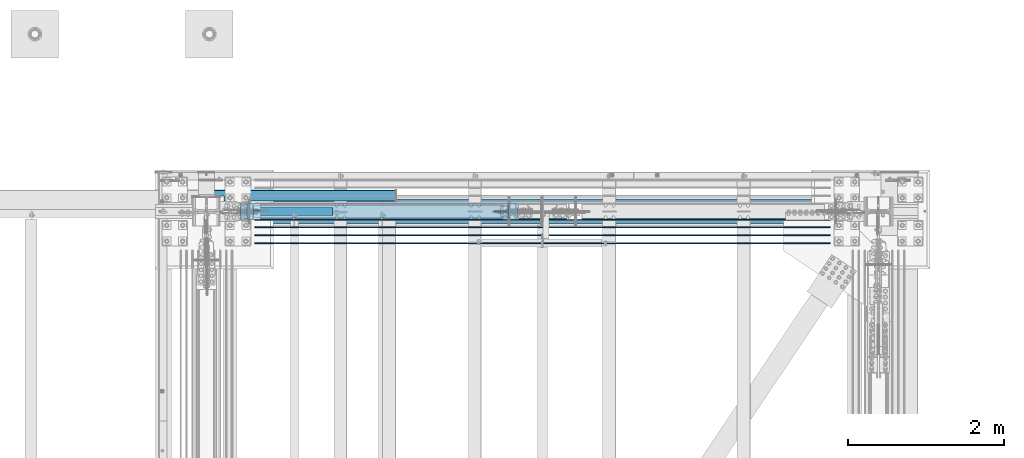
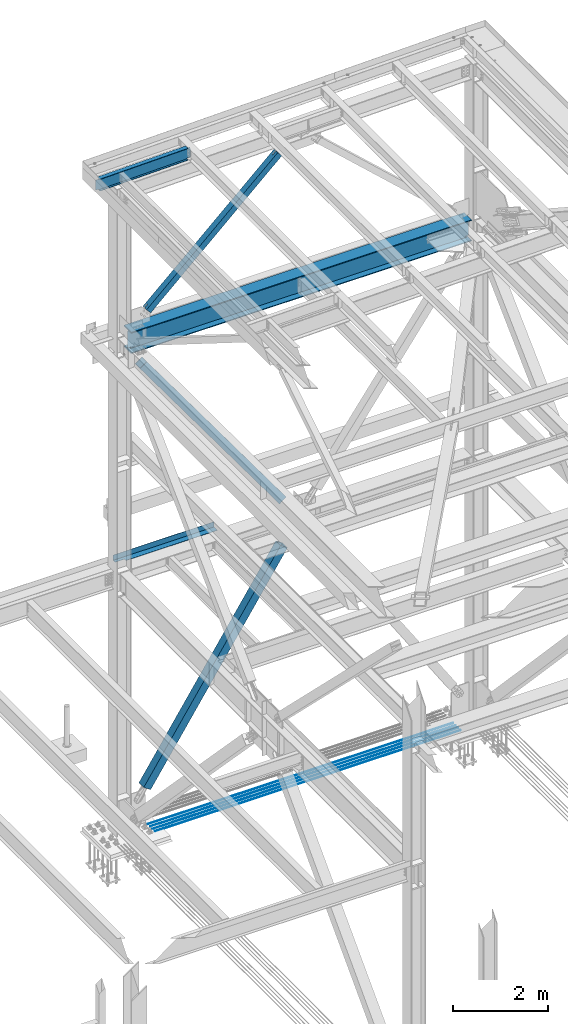
# One storey, part 1997 of 3843: 7 beams, 3 members, 10 elements without a shape of their own.
"""IFC2X3 building model written with IfcOpenShell, lengths in millimetres."""

from ifc_helpers import new_model, si_unit, frame, origin_with_axes, place, context, subcontext, project, spatial, faceted_brep, material, type_object, element, aggregate, save


model = new_model("IFC2X3")

# Units and contexts
model_context = context("Model", 3, precision=1e-05, world=origin_with_axes())
body_context = subcontext(model_context, "Body", "Model", "MODEL_VIEW")
ifc_project = project(units=[si_unit("LENGTHUNIT", "METRE", prefix="MILLI"), si_unit("AREAUNIT", "SQUARE_METRE"), si_unit("VOLUMEUNIT", "CUBIC_METRE"), si_unit("MASSUNIT", "GRAM", prefix="KILO"), si_unit("TIMEUNIT", "SECOND"), si_unit("PLANEANGLEUNIT", "RADIAN"), si_unit("SOLIDANGLEUNIT", "STERADIAN"), si_unit("THERMODYNAMICTEMPERATUREUNIT", "DEGREE_CELSIUS"), si_unit("LUMINOUSINTENSITYUNIT", "LUMEN")], contexts=[model_context])

# Site, building, storey
site_placement = place(None, origin_with_axes())
site = spatial("IfcSite", under=ifc_project, at=site_placement, CompositionType="ELEMENT")
building_placement = place(site_placement, origin_with_axes())
building = spatial("IfcBuilding", under=site, at=building_placement, Name="Undefined", CompositionType="ELEMENT")
storey_placement = place(building_placement, origin_with_axes())
storey = spatial("IfcBuildingStorey", under=building, at=storey_placement, Name="Undefined", CompositionType="ELEMENT", Elevation=0.0)

# Assembly, beam
assembly_1_placement = place(storey_placement, origin_with_axes())
assembly_1 = element("IfcElementAssembly", 1, at=assembly_1_placement, inside=storey, Name="REBAR", AssemblyPlace="NOTDEFINED", PredefinedType="RIGID_FRAME")
ifc_material_1 = material(Name="STEEL/A706-60")
beam_type_1 = type_object("IfcBeamType", Name="#10 REBAR", PredefinedType="NOTDEFINED")
beam_1_placement = place(assembly_1_placement, frame((77635.0999804674, 104152.7, 29700.5375), z_axis=(0.0, 0.0, 1.0), x_axis=(1.0, 0.0, 0.0)))
beam_1 = element("IfcBeam", 2, at=beam_1_placement, type_object=beam_type_1, material=ifc_material_1, Name="REBAR", ObjectType="#10 REBAR", context=body_context, shape_type="Brep", body=[
    faceted_brep([(0.0, -7.9375, 0.0), (0.0, -5.61266007566883, -5.61266007566883), (7391.48749999408, -5.61266007566883, -5.61266007566883), (7391.48749999408, -7.9375, 0.0), (0.0, 0.0, -7.9375), (7391.48749999408, 0.0, -7.9375), (0.0, 5.61266007566883, -5.61266007566883), (7391.48749999408, 5.61266007566883, -5.61266007566883), (0.0, 7.9375, 0.0), (7391.48749999408, 7.9375, 0.0), (0.0, 5.61266007566883, 5.61266007566883), (7391.48749999408, 5.61266007566883, 5.61266007566883), (0.0, 0.0, 7.9375), (7391.48749999408, 0.0, 7.9375), (0.0, -5.61266007566883, 5.61266007566883), (7391.48749999408, -5.61266007566883, 5.61266007566883)], [[[0, 1, 2, 3]], [[1, 4, 5, 2]], [[4, 6, 7, 5]], [[6, 8, 9, 7]], [[8, 10, 11, 9]], [[10, 12, 13, 11]], [[12, 14, 15, 13]], [[14, 0, 3, 15]], [[5, 7, 9, 11, 13, 15, 3, 2]], [[14, 12, 10, 8, 6, 4, 1, 0]]]),
])
aggregate(assembly_1, [beam_1])

assembly_2_placement = place(storey_placement, origin_with_axes())
assembly_2 = element("IfcElementAssembly", 3, at=assembly_2_placement, inside=storey, Name="REBAR", AssemblyPlace="NOTDEFINED", PredefinedType="RIGID_FRAME")
beam_2_placement = place(assembly_2_placement, frame((77635.0999804674, 104254.3, 29700.5375), z_axis=(0.0, 0.0, 1.0), x_axis=(1.0, 0.0, 0.0)))
beam_2 = element("IfcBeam", 4, at=beam_2_placement, type_object=beam_type_1, material=ifc_material_1, Name="REBAR", ObjectType="#10 REBAR", context=body_context, shape_type="Brep", body=[
    faceted_brep([(0.0, -7.9375, 0.0), (0.0, -5.61266007566883, -5.61266007566883), (7391.48749999408, -5.61266007566883, -5.61266007566883), (7391.48749999408, -7.9375, 0.0), (0.0, 0.0, -7.9375), (7391.48749999408, 0.0, -7.9375), (0.0, 5.61266007566883, -5.61266007566883), (7391.48749999408, 5.61266007566883, -5.61266007566883), (0.0, 7.9375, 0.0), (7391.48749999408, 7.9375, 0.0), (0.0, 5.61266007566883, 5.61266007566883), (7391.48749999408, 5.61266007566883, 5.61266007566883), (0.0, 0.0, 7.9375), (7391.48749999408, 0.0, 7.9375), (0.0, -5.61266007566883, 5.61266007566883), (7391.48749999408, -5.61266007566883, 5.61266007566883)], [[[0, 1, 2, 3]], [[1, 4, 5, 2]], [[4, 6, 7, 5]], [[6, 8, 9, 7]], [[8, 10, 11, 9]], [[10, 12, 13, 11]], [[12, 14, 15, 13]], [[14, 0, 3, 15]], [[5, 7, 9, 11, 13, 15, 3, 2]], [[14, 12, 10, 8, 6, 4, 1, 0]]]),
])
aggregate(assembly_2, [beam_2])

assembly_3_placement = place(storey_placement, origin_with_axes())
assembly_3 = element("IfcElementAssembly", 5, at=assembly_3_placement, inside=storey, Name="REBAR", AssemblyPlace="NOTDEFINED", PredefinedType="RIGID_FRAME")
beam_3_placement = place(assembly_3_placement, frame((77635.0999804674, 104355.9, 29700.5375), z_axis=(0.0, 0.0, 1.0), x_axis=(1.0, 0.0, 0.0)))
beam_3 = element("IfcBeam", 6, at=beam_3_placement, type_object=beam_type_1, material=ifc_material_1, Name="REBAR", ObjectType="#10 REBAR", context=body_context, shape_type="Brep", body=[
    faceted_brep([(0.0, -7.9375, 0.0), (0.0, -5.61266007566883, -5.61266007566883), (7391.48749999408, -5.61266007566883, -5.61266007566883), (7391.48749999408, -7.9375, 0.0), (0.0, 0.0, -7.9375), (7391.48749999408, 0.0, -7.9375), (0.0, 5.61266007566883, -5.61266007566883), (7391.48749999408, 5.61266007566883, -5.61266007566883), (0.0, 7.9375, 0.0), (7391.48749999408, 7.9375, 0.0), (0.0, 5.61266007566883, 5.61266007566883), (7391.48749999408, 5.61266007566883, 5.61266007566883), (0.0, 0.0, 7.9375), (7391.48749999408, 0.0, 7.9375), (0.0, -5.61266007566883, 5.61266007566883), (7391.48749999408, -5.61266007566883, 5.61266007566883)], [[[0, 1, 2, 3]], [[1, 4, 5, 2]], [[4, 6, 7, 5]], [[6, 8, 9, 7]], [[8, 10, 11, 9]], [[10, 12, 13, 11]], [[12, 14, 15, 13]], [[14, 0, 3, 15]], [[5, 7, 9, 11, 13, 15, 3, 2]], [[14, 12, 10, 8, 6, 4, 1, 0]]]),
])
aggregate(assembly_3, [beam_3])

assembly_4_placement = place(storey_placement, origin_with_axes())
assembly_4 = element("IfcElementAssembly", 7, at=assembly_4_placement, inside=storey, Name="REBAR", AssemblyPlace="NOTDEFINED", PredefinedType="RIGID_FRAME")
beam_4_placement = place(assembly_4_placement, frame((77635.0999804674, 104457.5, 29700.5375), z_axis=(0.0, 0.0, 1.0), x_axis=(1.0, 0.0, 0.0)))
beam_4 = element("IfcBeam", 8, at=beam_4_placement, type_object=beam_type_1, material=ifc_material_1, Name="REBAR", ObjectType="#10 REBAR", context=body_context, shape_type="Brep", body=[
    faceted_brep([(0.0, -7.9375, 0.0), (0.0, -5.61266007566883, -5.61266007566883), (7391.48749999408, -5.61266007566883, -5.61266007566883), (7391.48749999408, -7.9375, 0.0), (0.0, 0.0, -7.9375), (7391.48749999408, 0.0, -7.9375), (0.0, 5.61266007566883, -5.61266007566883), (7391.48749999408, 5.61266007566883, -5.61266007566883), (0.0, 7.9375, 0.0), (7391.48749999408, 7.9375, 0.0), (0.0, 5.61266007566883, 5.61266007566883), (7391.48749999408, 5.61266007566883, 5.61266007566883), (0.0, 0.0, 7.9375), (7391.48749999408, 0.0, 7.9375), (0.0, -5.61266007566883, 5.61266007566883), (7391.48749999408, -5.61266007566883, 5.61266007566883)], [[[0, 1, 2, 3]], [[1, 4, 5, 2]], [[4, 6, 7, 5]], [[6, 8, 9, 7]], [[8, 10, 11, 9]], [[10, 12, 13, 11]], [[12, 14, 15, 13]], [[14, 0, 3, 15]], [[5, 7, 9, 11, 13, 15, 3, 2]], [[14, 12, 10, 8, 6, 4, 1, 0]]]),
])
aggregate(assembly_4, [beam_4])

assembly_5_placement = place(storey_placement, origin_with_axes())
assembly_5 = element("IfcElementAssembly", 9, at=assembly_5_placement, inside=storey, Name="BEAM", AssemblyPlace="NOTDEFINED", PredefinedType="RIGID_FRAME")
ifc_material_2 = material(Name="STEEL/A992")
beam_type_2 = type_object("IfcBeamType", Name="W21X101", PredefinedType="NOTDEFINED")
beam_5_placement = place(assembly_5_placement, frame((77012.8, 104559.1, 42197.3375), z_axis=(0.0, 0.0, 1.0), x_axis=(1.0, 0.0, 0.0)))
beam_5 = element("IfcBeam", 10, at=beam_5_placement, type_object=beam_type_2, material=ifc_material_2, Name="BEAM", ObjectType="W21X101", context=body_context, shape_type="Brep", body=[
    faceted_brep([(199.239600281406, -155.574999999997, 271.462500000001), (199.239600281406, 155.574999999997, 271.462500000001), (187.324999999997, 155.574999999997, 250.824999999997), (187.324999999997, 6.35000000000582, 250.824999999997), (187.324999999997, -6.35000000000582, 250.824999999997), (187.324999999997, -155.574999999997, 250.824999999997), (8442.32500000003, -155.574999999997, -271.462500000001), (8430.41038480254, -155.574999999997, -250.824999999997), (199.239615197468, -155.574999999997, -250.824999999997), (187.324999999997, -155.574999999997, -271.462500000001), (8442.32500000003, 155.574999999997, -271.462500000001), (187.324999999997, 155.574999999997, -271.462500000001), (8430.41038480254, 155.574999999997, -250.824999999997), (199.239615197468, 155.574999999997, -250.824999999997), (8430.41038480254, 6.35000000000582, -250.824999999997), (199.239615197468, 6.35000000000582, -250.824999999997), (8430.1811927738, 6.35000000000582, -250.427999944863), (8430.1811927738, -6.34999999999127, -250.427999944863), (8430.41038480254, -6.35000000000582, -250.824999999997), (8407.72699700929, 6.35000000003492, -250.427999877924), (8407.72699700929, -6.34999999999127, -250.427999877924), (8362.34209307106, 6.35000000003492, -234.406795662093), (8362.34209307106, -6.34999999999127, -234.406795662093), (8358.05273064335, 6.35000000003492, -231.347328768315), (8358.05273064335, -6.34999999999127, -231.347328768315), (8356.0458763951, 6.35000000003492, -226.475829642106), (8356.0458763951, -6.34999999999127, -226.475829642106), (8356.93555978866, 6.35000000003492, -221.282812102218), (8356.93555978866, -6.34999999999127, -221.282812102218), (8360.44956782385, 6.35000000003492, -217.357163717686), (8360.44956782385, -6.34999999999127, -217.357163717686), (8365.5127330009, 6.35000000003492, -215.899999999994), (8365.5127330009, -6.34999999999127, -215.899999999994), (8442.32500000003, -6.34999999999127, -215.900000000001), (8434.99265158315, 6.35000000006403, -215.900000000001), (8434.99265158315, 6.35000000006403, 215.900000000001), (8442.325, -6.34999999996217, 215.900000000001), (8365.1857385246, 6.35000000003492, 215.899999999994), (8365.1857385246, -6.34999999999127, 215.899999999994), (8360.12257336729, 6.35000000003492, 217.357163705296), (8360.12257336729, -6.34999999999127, 217.357163705296), (8356.60856533264, 6.35000000003492, 221.282812060221), (8356.60856533264, -6.34999999999127, 221.282812060221), (8355.71888191109, 6.35000000003492, 226.47582957257), (8355.71888191109, -6.34999999999127, 226.47582957257), (8357.72573610905, 6.35000000003492, 231.34732869525), (8357.72573610905, -6.34999999999127, 231.34732869525), (8362.0150984848, 6.35000000003492, 234.406795623283), (8362.0150984848, -6.34999999999127, 234.406795623283), (8407.40000076295, 6.35000000003492, 250.427999877924), (8407.40000076295, -6.34999999999127, 250.427999877924), (8442.32500000003, 6.35000000000582, 250.427999981221), (8442.32500000003, -6.34999999999127, 250.427999981221), (8442.32500000003, 6.35000000000582, 250.824999999997), (8442.32500000003, -6.35000000000582, 250.824999999997), (8442.32500000003, -155.574999999997, 250.824999999997), (8442.32500000003, 155.574999999997, 250.824999999997), (8430.41039971862, 155.574999999997, 271.462500000001), (8430.41039971862, -155.574999999997, 271.462500000001), (187.324999999997, 6.35000000000582, 250.427999981221), (187.324999999997, -6.35000000000582, 250.427999981221), (222.249999237058, 6.34999999999127, 250.427999877924), (222.249999237058, -6.35000000000582, 250.427999877924), (267.634901515208, 6.34999999999127, 234.406795623283), (267.634901515208, -6.35000000000582, 234.406795623283), (271.924263890964, 6.34999999999127, 231.34732869525), (271.924263890964, -6.35000000000582, 231.34732869525), (273.93111808892, 6.34999999999127, 226.47582957257), (273.93111808892, -6.35000000000582, 226.47582957257), (273.041434667364, 6.34999999999127, 221.282812060221), (273.041434667364, -6.35000000000582, 221.282812060221), (269.527426632703, 6.34999999999127, 217.357163705296), (269.527426632703, -6.35000000000582, 217.357163705296), (264.464261475412, 6.34999999999127, 215.899999999994), (264.464261475412, -6.35000000000582, 215.899999999994), (194.657348416848, 6.35000000002037, 215.900000000001), (187.324999999997, -6.35000000000582, 215.900000000001), (194.657348416848, 6.35000000002037, -215.900000000001), (187.324999999997, -6.35000000000582, -215.900000000001), (264.137266999111, 6.34999999999127, -215.899999999994), (264.137266999111, -6.35000000000582, -215.899999999994), (269.200432176163, 6.34999999999127, -217.357163717686), (269.200432176163, -6.35000000000582, -217.357163717686), (272.714440211348, 6.34999999999127, -221.282812102218), (272.714440211348, -6.35000000000582, -221.282812102218), (273.604123604906, 6.34999999999127, -226.475829642106), (273.604123604906, -6.35000000000582, -226.475829642106), (271.597269356658, 6.34999999999127, -231.347328768315), (271.597269356658, -6.35000000000582, -231.347328768315), (267.307906928967, 6.34999999999127, -234.406795662093), (267.307906928967, -6.35000000000582, -234.406795662093), (221.923002990719, 6.34999999999127, -250.427999877924), (221.923002990719, -6.35000000000582, -250.427999877924), (199.468807226207, 6.34999999999127, -250.427999944863), (199.468807226207, -6.35000000000582, -250.427999944863), (199.239615197468, -6.35000000000582, -250.824999999997)], [[[0, 1, 2, 3, 4, 5]], [[6, 7, 8, 9]], [[10, 6, 9, 11]], [[12, 10, 11, 13]], [[14, 12, 13, 15]], [[6, 10, 12, 14, 16, 17, 18, 7]], [[19, 20, 17, 16]], [[20, 19, 21, 22]], [[22, 21, 23, 24]], [[24, 23, 25, 26]], [[26, 25, 27, 28]], [[28, 27, 29, 30]], [[30, 29, 31, 32]], [[33, 32, 31, 34]], [[33, 34, 35, 36]], [[36, 35, 37, 38]], [[38, 37, 39, 40]], [[40, 39, 41, 42]], [[42, 41, 43, 44]], [[44, 43, 45, 46]], [[46, 45, 47, 48]], [[48, 47, 49, 50]], [[50, 49, 51, 52]], [[52, 51, 53, 54]], [[55, 54, 53, 56, 57, 58]], [[55, 58, 0, 5]], [[54, 55, 5, 4]], [[59, 60, 4, 3]], [[61, 62, 60, 59]], [[62, 61, 63, 64]], [[64, 63, 65, 66]], [[66, 65, 67, 68]], [[68, 67, 69, 70]], [[70, 69, 71, 72]], [[72, 71, 73, 74]], [[74, 73, 75, 76]], [[77, 78, 76, 75]], [[78, 77, 79, 80]], [[80, 79, 81, 82]], [[82, 81, 83, 84]], [[84, 83, 85, 86]], [[86, 85, 87, 88]], [[88, 87, 89, 90]], [[90, 89, 91, 92]], [[92, 91, 93, 94]], [[18, 17, 20, 22, 24, 26, 28, 30, 32, 33, 36, 38, 40, 42, 44, 46, 48, 50, 52, 54, 4, 60, 62, 64, 66, 68, 70, 72, 74, 76, 78, 80, 82, 84, 86, 88, 90, 92, 94, 95]], [[7, 18, 95, 8]], [[94, 93, 15, 13, 11, 9, 8, 95]], [[91, 89, 87, 85, 83, 81, 79, 77, 75, 73, 71, 69, 67, 65, 63, 61, 59, 3, 53, 51, 49, 47, 45, 43, 41, 39, 37, 35, 34, 31, 29, 27, 25, 23, 21, 19, 16, 14, 15, 93]], [[56, 53, 3, 2]], [[57, 56, 2, 1]], [[58, 57, 1, 0]]]),
])
aggregate(assembly_5, [beam_5])

assembly_6_placement = place(storey_placement, origin_with_axes())
assembly_6 = element("IfcElementAssembly", 11, at=assembly_6_placement, inside=storey, Name="BEAM", AssemblyPlace="NOTDEFINED", PredefinedType="RIGID_FRAME")
beam_type_3 = type_object("IfcBeamType", Name="W12X19", PredefinedType="NOTDEFINED")
beam_6_placement = place(assembly_6_placement, frame((76406.4571597858, 104559.1, 46418.2589406452), z_axis=(-0.0211520980073474, 0.0, 0.999776269347241), x_axis=(0.999776270257024, 0.0, 0.0211520550054619)))
beam_6 = element("IfcBeam", 12, at=beam_6_placement, type_object=beam_type_3, material=ifc_material_2, Name="BEAM", ObjectType="W12X19", context=body_context, shape_type="Brep", body=[
    faceted_brep([(2232.3149825334, -3.17500000000291, -144.462499991867), (2232.3149825334, -50.8000000000029, -144.462499991867), (2232.31498253353, -50.8000000000029, -153.987499991876), (2232.31498253353, 50.8000000000029, -153.987499991876), (2232.3149825334, 50.8000000000029, -144.462499991867), (2232.3149825334, 3.17500000000291, -144.462499991867), (2232.31498253338, 3.17500000000291, -141.287499725579), (2232.31498253338, -3.17500000000291, -141.287499725579), (2233.28171245592, 3.17500000000291, -136.427420207467), (2233.28171245592, -3.17500000000291, -136.427420207467), (2236.03472635635, 3.17500000000291, -132.307243739255), (2236.03472635635, -3.17500000000291, -132.307243739255), (2240.15490282445, 3.17500000000291, -129.554229838737), (2240.15490282445, -3.17500000000291, -129.554229838737), (2245.01498234246, 3.17500000000291, -128.587499916146), (2245.01498234246, -3.17500000000291, -128.587499916146), (2314.86498100203, -3.17500000000291, -128.587499916357), (2314.86498100203, 3.17500000000291, -128.587499916357), (96.8374980314547, 3.17500000000291, 144.462500000489), (96.8374980314547, 50.8000000000029, 144.462500000489), (2232.31498253648, 50.8000000000029, 144.462500008405), (2232.31498253648, 3.17500000000291, 144.462500008405), (96.8374977455387, -3.17500000000291, -141.287499907492), (96.8374977455387, 3.17500000000291, -141.287499907492), (96.8374977423518, 3.17500000000291, -144.462499999776), (96.8374977423518, 50.8000000000029, -144.462499999776), (96.8374977328203, 50.8000000000029, -153.987499999792), (96.8374977328203, -50.8000000000029, -153.987499999792), (96.8374977423518, -50.8000000000029, -144.462499999776), (96.8374977423518, -3.17500000000291, -144.462499999776), (95.8707678278151, -3.17500000000291, -136.427420388471), (95.8707678278151, 3.17500000000291, -136.427420388471), (93.1177539315104, -3.17500000000291, -132.307243917545), (93.1177539315104, 3.17500000000291, -132.307243917545), (88.9975774661289, -3.17500000000291, -129.554230012938), (88.9975774661289, 3.17500000000291, -129.554230012938), (84.1374979491229, -3.17500000000291, -128.587500085479), (84.1374979491229, 3.17500000000291, -128.587500085479), (20.6374979119428, -3.17500000000291, -128.587500021946), (20.6374979119428, 3.17500000000291, -128.587500021946), (20.637498196942, -3.17499999998836, -114.712499731744), (20.637499580218, -3.17499999998836, 115.887500264478), (20.637499711811, -3.17500000000291, 128.587499979069), (20.637499711811, 3.17500000000291, 128.587499979069), (84.1374982064444, -3.17500000000291, 128.587499915513), (84.1374982064444, 3.17500000000291, 128.587499915513), (88.9975777254003, -3.17500000000291, 129.554229833244), (88.9975777254003, 3.17500000000291, 129.554229833244), (93.1177541962679, -3.17500000000291, 132.307243729607), (93.1177541962679, 3.17500000000291, 132.307243729607), (95.8707681008382, -3.17500000000291, 136.427420195025), (95.8707681008382, 3.17500000000291, 136.427420195025), (96.8374980282824, -3.17500000000291, 141.287499712118), (96.8374980282824, 3.17500000000291, 141.287499712118), (96.8374980410154, -50.8000000000029, 153.987499285155), (96.8374980410008, 50.8000000000029, 153.987500000498), (96.8374980314547, -3.17500000000291, 144.462500000489), (96.8374980314547, -50.8000000000029, 144.462500000489), (2232.31498253648, -3.17500000000291, 144.462500008405), (2232.31498253648, -50.8000000000029, 144.462500008405), (2232.31498253638, -50.8000000000029, 153.987499981791), (2232.31498253639, 50.8000000000029, 153.987500008421), (2232.31498253651, -3.17500000000291, 141.28749989366), (2232.31498253651, 3.17500000000291, 141.28749989366), (2233.28171245912, -3.17500000000291, 136.427420375658), (2233.28171245912, 3.17500000000291, 136.427420375658), (2236.03472635955, -3.17500000000291, 132.30724390754), (2236.03472635955, 3.17500000000291, 132.30724390754), (2240.15490282758, -3.17500000000291, 129.554230007096), (2240.15490282758, 3.17500000000291, 129.554230007096), (2245.0149823455, -3.17500000000291, 128.587500084504), (2245.0149823455, 3.17500000000291, 128.587500084504), (2314.86498280188, -3.17500000000291, 128.58750008425), (2314.86498280188, 3.17500000000291, 128.58750008425), (2314.86498270548, -3.17499999998836, 115.887499732082), (2314.86498132217, -3.17499999998836, -114.712500265654)], [[[0, 1, 2, 3, 4, 5, 6, 7]], [[7, 6, 8, 9]], [[9, 8, 10, 11]], [[11, 10, 12, 13]], [[13, 12, 14, 15]], [[16, 15, 14, 17]], [[18, 19, 20, 21]], [[22, 23, 24, 25, 26, 27, 28, 29]], [[30, 31, 23, 22]], [[32, 33, 31, 30]], [[34, 35, 33, 32]], [[36, 37, 35, 34]], [[38, 39, 37, 36]], [[40, 41, 42, 43, 39, 38]], [[44, 45, 43, 42]], [[46, 47, 45, 44]], [[48, 49, 47, 46]], [[50, 51, 49, 48]], [[52, 53, 51, 50]], [[54, 55, 19, 18, 53, 52, 56, 57]], [[57, 56, 58, 59]], [[54, 57, 59, 60]], [[55, 54, 60, 61]], [[19, 55, 61, 20]], [[60, 59, 58, 62, 63, 21, 20, 61]], [[64, 65, 63, 62]], [[66, 67, 65, 64]], [[68, 69, 67, 66]], [[70, 71, 69, 68]], [[72, 73, 71, 70]], [[73, 72, 74, 75, 16, 17]], [[12, 10, 8, 6, 5, 24, 23, 31, 33, 35, 37, 39, 43, 45, 47, 49, 51, 53, 18, 21, 63, 65, 67, 69, 71, 73, 17, 14]], [[25, 24, 5, 4]], [[26, 25, 4, 3]], [[27, 26, 3, 2]], [[28, 27, 2, 1]], [[29, 28, 1, 0]], [[75, 74, 72, 70, 68, 66, 64, 62, 58, 56, 52, 50, 48, 46, 44, 42, 41, 40, 38, 36, 34, 32, 30, 22, 29, 0, 7, 9, 11, 13, 15, 16]]]),
])
aggregate(assembly_6, [beam_6])

# Assembly, member
assembly_7_placement = place(storey_placement, origin_with_axes())
assembly_7 = element("IfcElementAssembly", 13, at=assembly_7_placement, inside=storey, Name="None", AssemblyPlace="NOTDEFINED", PredefinedType="RIGID_FRAME")
member_type_1 = type_object("IfcMemberType", Name="HSS8X8X3/16", PredefinedType="NOTDEFINED")
member_1_placement = place(assembly_7_placement, frame((80905.3945590918, 104559.1, 36837.8644556643), z_axis=(0.0, 1.0, 0.0), x_axis=(-0.587657745235489, 0.0, 0.809109618324206)))
member_1 = element("IfcMember", 14, at=member_1_placement, type_object=member_type_1, material=ifc_material_2, Name="None", ObjectType="HSS8X8X3/16", context=body_context, shape_type="Brep", body=[
    faceted_brep([(2.03726813197136e-10, 96.8375000003298, -96.8374999999942), (-2.18278728425503e-10, -96.837500000317, -96.8374999999942), (5746.74999994003, -96.8374999603548, -96.8374999999942), (5746.74999994067, 96.8375000390515, -96.8374999999942), (-2.18278728425503e-10, -96.837500000317, 96.8374999999942), (5746.74999994003, -96.8374999603548, 96.8374999999942), (2.03726813197136e-10, 96.8375000003298, 96.8374999999942), (5746.74999994067, 96.8375000390515, 96.8374999999942), (2.18278728425503e-10, 101.600000000345, -101.600000000006), (2.18278728425503e-10, 101.600000000345, 101.600000000006), (5746.74999994069, 101.600000039034, 101.600000000006), (5746.74999994069, 101.600000039034, -101.600000000006), (-2.25554686039686e-10, -101.600000000329, 101.600000000006), (5746.74999994002, -101.599999960352, 101.600000000006), (-2.25554686039686e-10, -101.600000000329, -101.600000000006), (5746.74999994002, -101.599999960352, -101.600000000006)], [[[0, 1, 2, 3]], [[1, 4, 5, 2]], [[4, 6, 7, 5]], [[6, 0, 3, 7]], [[8, 9, 10, 11]], [[9, 12, 13, 10]], [[12, 14, 15, 13]], [[14, 8, 11, 15]], [[13, 15, 11, 10], [5, 7, 3, 2]], [[14, 12, 9, 8], [6, 4, 1, 0]]]),
])
aggregate(assembly_7, [member_1])

assembly_8_placement = place(storey_placement, origin_with_axes())
assembly_8 = element("IfcElementAssembly", 15, at=assembly_8_placement, inside=storey, Name="None", AssemblyPlace="NOTDEFINED", PredefinedType="RIGID_FRAME")
member_2_placement = place(assembly_8_placement, frame((77620.3173807129, 104559.1, 30615.4903758925), z_axis=(0.0, -1.0, 0.0), x_axis=(0.549839243795952, 0.0, 0.835270498690032)))
member_2 = element("IfcMember", 16, at=member_2_placement, type_object=member_type_1, material=ifc_material_2, Name="None", ObjectType="HSS8X8X3/16", context=body_context, shape_type="Brep", body=[
    faceted_brep([(2.03726813197136e-10, 96.8375000003298, -96.8374999999942), (-2.18278728425503e-10, -96.837500000317, -96.8374999999942), (6026.15000014934, -96.8375000308661, -96.8374999999942), (6026.15000014917, 96.837499969035, -96.8374999999942), (-2.18278728425503e-10, -96.837500000317, 96.8374999999942), (6026.15000014934, -96.8375000308661, 96.8374999999942), (2.03726813197136e-10, 96.8375000003298, 96.8374999999942), (6026.15000014917, 96.837499969035, 96.8374999999942), (2.18278728425503e-10, 101.600000000345, -101.600000000006), (2.18278728425503e-10, 101.600000000345, 101.600000000006), (6026.15000014915, 101.599999969032, 101.600000000006), (6026.15000014915, 101.599999969032, -101.600000000006), (-2.25554686039686e-10, -101.600000000329, 101.600000000006), (6026.15000014936, -101.600000030849, 101.600000000006), (-2.25554686039686e-10, -101.600000000329, -101.600000000006), (6026.15000014936, -101.600000030849, -101.600000000006)], [[[0, 1, 2, 3]], [[1, 4, 5, 2]], [[4, 6, 7, 5]], [[6, 0, 3, 7]], [[8, 9, 10, 11]], [[9, 12, 13, 10]], [[12, 14, 15, 13]], [[14, 8, 11, 15]], [[13, 15, 11, 10], [5, 7, 3, 2]], [[14, 12, 9, 8], [6, 4, 1, 0]]]),
])
aggregate(assembly_8, [member_2])

assembly_9_placement = place(storey_placement, origin_with_axes())
assembly_9 = element("IfcElementAssembly", 17, at=assembly_9_placement, inside=storey, AssemblyPlace="NOTDEFINED", PredefinedType="RIGID_FRAME")
ifc_material_3 = material()
member_type_2 = type_object("IfcMemberType", Name="HSS6X6X3/8", PredefinedType="NOTDEFINED")
member_3_placement = place(assembly_9_placement, frame((77012.8, 104559.1, 42197.3375), z_axis=(0.675885212782439, 0.0, -0.737006905762787), x_axis=(0.737006905762787, 0.0, 0.675885212782439)))
member_3 = element("IfcMember", 18, at=member_3_placement, type_object=member_type_2, material=ifc_material_3, ObjectType="HSS6X6X3/8", context=body_context, shape_type="Brep", body=[
    faceted_brep([(890.829571245849, -4.76249999999709, 76.200000001656), (890.829571245849, -4.76249999999709, 66.6750000016364), (990.842071246429, -4.76249999999709, 66.6750000018183), (990.842071246414, -4.76249999999709, 76.2000000018343), (993.879620990832, -5.36670621068333, 66.6750000018146), (993.879620990818, -5.36670621068333, 76.2000000018306), (996.454731322126, -7.08733992432826, 66.6750000018255), (996.454731322112, -7.08733992432826, 76.2000000018343), (998.175365035771, -9.66245025559328, 66.6750000018255), (998.175365035771, -9.66245025559328, 76.2000000018452), (990.842071246414, -20.6374999999971, 76.2000000018343), (990.842071246429, -20.6374999999971, 66.6750000018183), (890.829571245849, -20.6374999999971, 66.6750000016364), (890.829571245849, -20.6374999999971, 76.200000001656), (993.879620990818, -20.0332937893108, 76.2000000018306), (993.879620990832, -20.0332937893108, 66.6750000018146), (996.454731322112, -18.3126600756659, 76.2000000018343), (996.454731322126, -18.3126600756659, 66.6750000018255), (998.175365035771, -15.7375497444009, 76.2000000018452), (998.175365035771, -15.7375497444009, 66.6750000018255), (998.779571246458, -12.6999999999971, 76.2000000018452), (998.779571246472, -12.6999999999971, 66.6750000018292), (890.829571245849, -4.76249999999709, -66.6749999985805), (890.829571245849, -4.76249999999709, -76.1999999985928), (990.842071246676, -4.76249999999709, -76.1999999984255), (990.842071246661, -4.76249999999709, -66.6749999984095), (993.87962099108, -5.36670621068333, -76.1999999984146), (993.879620991065, -5.36670621068333, -66.6749999984058), (996.454731322359, -7.08733992432826, -76.1999999984182), (996.454731322359, -7.08733992432826, -66.6749999984058), (998.175365036033, -9.66245025559328, -76.1999999984073), (998.175365036004, -9.66245025559328, -66.6749999983986), (990.842071246661, -20.6374999999971, -66.6749999984095), (990.842071246676, -20.6374999999971, -76.1999999984255), (890.829571245849, -20.6374999999971, -76.1999999985928), (890.829571245849, -20.6374999999971, -66.6749999985805), (993.879620991065, -20.0332937893108, -66.6749999984058), (993.87962099108, -20.0332937893108, -76.1999999984146), (996.454731322359, -18.3126600756659, -66.6749999984058), (996.454731322359, -18.3126600756659, -76.1999999984182), (998.175365036004, -15.7375497444009, -66.6749999983986), (998.175365036033, -15.7375497444009, -76.1999999984073), (998.77957124669, -12.6999999999971, -66.6749999983986), (998.77957124672, -12.6999999999971, -76.1999999984146), (890.829571245849, 66.6750000000029, 66.6750000016364), (890.829571245849, 66.6750000000029, -66.6749999985805), (5199.22603317711, 66.6750000000029, -66.674999991199), (5199.22603317711, 66.6750000000029, 66.6750000090324), (890.829571245849, 76.1999999999971, -76.1999999985928), (5199.22603317711, 76.1999999999971, -76.1999999912005), (5199.22603317711, 7.9375, -76.1999999912005), (5099.213533173, 7.9375, -76.1999999913751), (5096.17598342858, 7.33329378931376, -76.1999999913824), (5093.60087309728, 5.61266007566883, -76.1999999913896), (5091.88023938364, 3.0375497444038, -76.1999999913969), (5091.27603317295, 0.0, -76.1999999913824), (5091.88023938364, -3.0375497444038, -76.1999999913969), (5093.60087309728, -5.61266007566883, -76.1999999913896), (5096.17598342858, -7.33329378931376, -76.1999999913824), (5099.213533173, -7.9375, -76.1999999913751), (5199.22603317711, -7.9375, -76.1999999912005), (5199.22603317711, -76.1999999999971, -76.1999999912005), (890.829571245849, -76.1999999999971, -76.1999999985928), (5199.22603317711, 7.9375, -66.674999991199), (5099.21353317297, 7.9375, -66.6749999913591), (5096.17598342856, 7.33329378931376, -66.6749999913663), (5093.60087309727, 5.61266007566883, -66.6749999913736), (5091.88023938362, 3.0375497444038, -66.6749999913809), (5091.27603317292, 0.0, -66.6749999913809), (5091.88023938362, -3.0375497444038, -66.6749999913809), (5093.60087309727, -5.61266007566883, -66.6749999913736), (5096.17598342856, -7.33329378931376, -66.6749999913663), (5099.21353317297, -7.9375, -66.6749999913591), (5199.22603317711, -7.9375, -66.674999991199), (890.829571245849, -66.6750000000029, -66.6749999985805), (890.829571245849, -66.6750000000029, 66.6750000016364), (5199.22603317711, -66.6750000000029, 66.6750000090324), (5199.22603317711, -66.6750000000029, -66.674999991199), (5096.1759834283, 7.33329378931376, 76.2000000088665), (5096.17598342831, 7.33329378931376, 66.6750000088505), (5099.21353317273, 7.9375, 66.6750000088578), (5099.21353317273, 7.9375, 76.2000000088738), (5093.60087309702, 5.61266007566883, 76.2000000088665), (5093.60087309705, 5.61266007566883, 66.6750000088505), (5091.88023938338, 3.0375497444038, 76.2000000088592), (5091.8802393834, 3.0375497444038, 66.6750000088505), (5091.27603317267, 0.0, 76.2000000088592), (5091.2760331727, 0.0, 66.6750000088432), (5091.88023938338, -3.0375497444038, 76.2000000088592), (5091.8802393834, -3.0375497444038, 66.6750000088505), (5093.60087309702, -5.61266007566883, 76.2000000088665), (5093.60087309705, -5.61266007566883, 66.6750000088505), (5096.1759834283, -7.33329378931376, 76.2000000088665), (5096.17598342831, -7.33329378931376, 66.6750000088505), (5099.21353317273, -7.9375, 76.2000000088738), (5099.21353317273, -7.9375, 66.6750000088578), (5199.22603317711, -7.9375, 76.2000000090411), (5199.22603317711, -7.9375, 66.6750000090324), (5199.22603317711, -76.1999999999971, 76.2000000090411), (890.829571245849, -76.1999999999971, 76.200000001656), (5199.22603317711, 7.9375, 66.6750000090324), (5199.22603317711, 7.9375, 76.2000000090411), (5199.22603317711, 76.1999999999971, 76.2000000090411), (890.829571245849, 76.1999999999971, 76.200000001656)], [[[0, 1, 2, 3]], [[3, 2, 4, 5]], [[5, 4, 6, 7]], [[7, 6, 8, 9]], [[10, 11, 12, 13]], [[14, 15, 11, 10]], [[16, 17, 15, 14]], [[18, 19, 17, 16]], [[20, 21, 19, 18]], [[9, 8, 21, 20]], [[22, 23, 24, 25]], [[25, 24, 26, 27]], [[27, 26, 28, 29]], [[29, 28, 30, 31]], [[32, 33, 34, 35]], [[36, 37, 33, 32]], [[38, 39, 37, 36]], [[40, 41, 39, 38]], [[42, 43, 41, 40]], [[31, 30, 43, 42]], [[44, 45, 46, 47]], [[28, 26, 24, 23, 48, 49, 50, 51, 52, 53, 54, 55, 56, 57, 58, 59, 60, 61, 62, 34, 33, 37, 39, 41, 43, 30]], [[63, 64, 51, 50]], [[65, 52, 51, 64]], [[66, 53, 52, 65]], [[67, 54, 53, 66]], [[68, 55, 54, 67]], [[69, 56, 55, 68]], [[70, 57, 56, 69]], [[71, 58, 57, 70]], [[72, 59, 58, 71]], [[73, 60, 59, 72]], [[74, 75, 76, 77]], [[78, 79, 80, 81]], [[82, 83, 79, 78]], [[84, 85, 83, 82]], [[86, 87, 85, 84]], [[88, 89, 87, 86]], [[90, 91, 89, 88]], [[92, 93, 91, 90]], [[94, 95, 93, 92]], [[96, 97, 95, 94]], [[98, 61, 60, 73, 77, 76, 97, 96]], [[99, 62, 61, 98]], [[75, 74, 35, 34, 62, 99, 13, 12]], [[6, 4, 2, 1, 44, 47, 100, 80, 79, 83, 85, 87, 89, 91, 93, 95, 97, 76, 75, 12, 11, 15, 17, 19, 21, 8]], [[101, 81, 80, 100]], [[47, 46, 63, 50, 49, 102, 101, 100]], [[48, 103, 102, 49]], [[16, 14, 10, 13, 99, 98, 96, 94, 92, 90, 88, 86, 84, 82, 78, 81, 101, 102, 103, 0, 3, 5, 7, 9, 20, 18]], [[103, 48, 23, 22, 45, 44, 1, 0]], [[38, 36, 32, 35, 74, 77, 73, 72, 71, 70, 69, 68, 67, 66, 65, 64, 63, 46, 45, 22, 25, 27, 29, 31, 42, 40]]]),
])
aggregate(assembly_9, [member_3])

# Assembly, beam
assembly_10_placement = place(storey_placement, origin_with_axes())
assembly_10 = element("IfcElementAssembly", 19, at=assembly_10_placement, inside=storey, Name="BEAM", AssemblyPlace="NOTDEFINED", PredefinedType="RIGID_FRAME")
ifc_material_4 = material(Name="STEEL/A36")
beam_type_4 = type_object("IfcBeamType", PredefinedType="NOTDEFINED")
beam_7_placement = place(assembly_10_placement, frame((78233.5875, 104694.038, 36439.475), z_axis=(-1.0, 0.0, 0.0), x_axis=(0.0, 1.0, 0.0)))
beam_7 = element("IfcBeam", 20, at=beam_7_placement, type_object=beam_type_4, material=ifc_material_4, Name="BENT_PLATE", context=body_context, shape_type="Brep", body=[
    faceted_brep([(61.9119938965741, -3.17500000000291, 993.775000000009), (61.9119938965741, 3.17500000000291, 993.775000000009), (0.0, 3.17500000000291, 993.775000000009), (0.0, -3.17500000000291, 993.775000000009), (61.9119938965014, -3.17500000000291, 1220.78750000001), (61.9119938965014, 3.17500000000291, 1220.78750000001), (138.112005615229, -3.17500000000291, -1220.78750000001), (0.0, -3.17500000000291, -1220.78750000001), (0.0, 3.17500000000291, -1220.78750000001), (144.462005615234, 3.17500000000291, -1220.78750000001), (144.462005615234, -136.524996948239, -1220.78750000001), (138.112005615229, -136.524996948239, -1220.78750000001), (144.462005615234, 3.17500000000291, 1220.78750000001), (144.462005615234, -136.524996948239, 1220.78750000001), (138.112005615229, -136.524996948239, 1220.78750000001), (138.112005615229, -3.17500000000291, 1220.78750000001)], [[[0, 1, 2, 3]], [[4, 5, 1, 0]], [[6, 7, 8, 9, 10, 11]], [[9, 12, 13, 10]], [[14, 11, 10, 13]], [[15, 6, 11, 14]], [[3, 7, 6, 15, 4, 0]], [[8, 7, 3, 2]], [[12, 9, 8, 2, 1, 5]], [[15, 14, 13, 12, 5, 4]]]),
])
aggregate(assembly_10, [beam_7])

save(model, "model.ifc")
